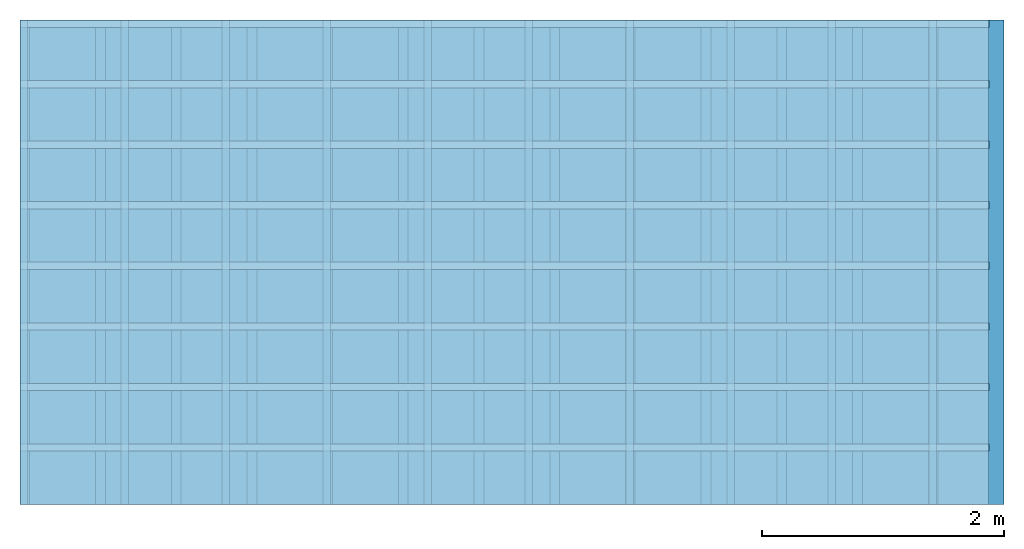
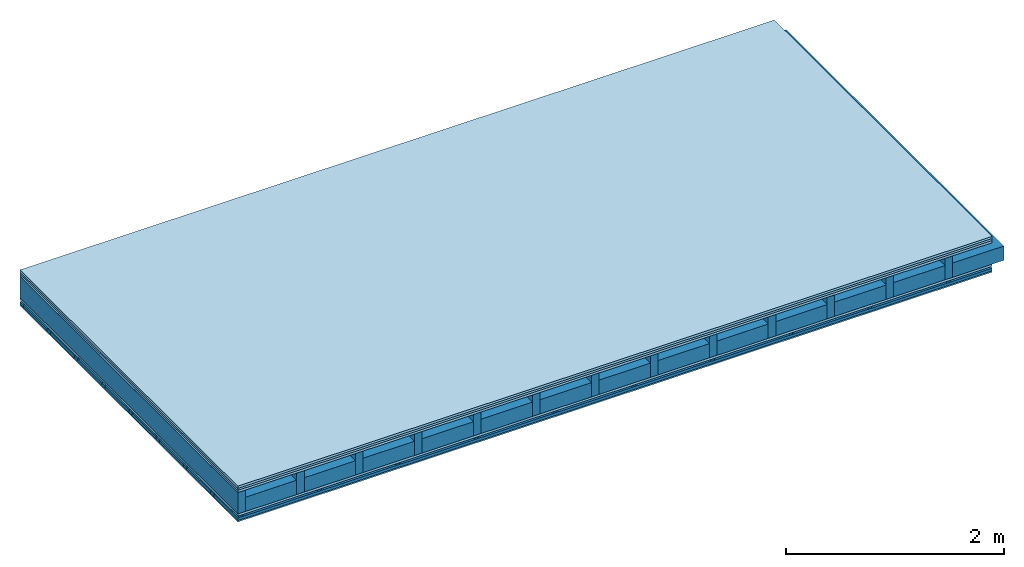
# One storey: 5 members, 5 plates, 1 element without a shape of its own.
"""IFC4 building model written with IfcOpenShell, lengths in metres."""

from ifc_helpers import new_model, si_unit, derived_unit, direction, frame, frame_2d, origin, origin_with_axes, place, context, project, spatial, polyline, rectangle, outline, extrude, material, layer, layer_set, type_object, element, aggregate, save


model = new_model("IFC4")

# Units and contexts
plan_context = context("Plan", 3, precision=1e-05, world=origin(), true_north=direction((0.0, 1.0)))
model_context = context("Model", 3, precision=1e-05, world=origin(), true_north=direction((0.0, 1.0)))
ifc_project = project(units=[si_unit("LENGTHUNIT", "METRE"), derived_unit("SOUNDPRESSUREUNIT", [(si_unit("PRESSUREUNIT", "PASCAL", prefix="MICRO"), 0)]), si_unit("ENERGYUNIT", "JOULE", prefix="MEGA"), si_unit("MASSUNIT", "GRAM", prefix="KILO"), derived_unit("THERMALTRANSMITTANCEUNIT", [(si_unit("POWERUNIT", "WATT"), 1), (si_unit("AREAUNIT", "SQUARE_METRE"), -1), (si_unit("THERMODYNAMICTEMPERATUREUNIT", "KELVIN"), -1)]), derived_unit("AREADENSITYUNIT", [(si_unit("MASSUNIT", "GRAM", prefix="KILO"), 1), (si_unit("AREAUNIT", "SQUARE_METRE"), -1)]), derived_unit("USERDEFINED", [(si_unit("ENERGYUNIT", "JOULE", prefix="MEGA"), 1), (si_unit("AREAUNIT", "SQUARE_METRE"), -1)])], contexts=[plan_context, model_context])

# Site, building, storey
site = spatial("IfcSite", under=ifc_project)
building_placement = place(None, origin())
building = spatial("IfcBuilding", under=site, at=building_placement)
storey_placement = place(building_placement, origin())
storey = spatial("IfcBuildingStorey", under=building, at=storey_placement)

# Slab, members, plates
ifc_material_1 = material(Name="Floor heating system Therm38 longitudinal", Category="03.007")
ifc_layer_1 = layer(ifc_material_1, 0.025, Name="On-material")
ifc_material_2 = material(Category="10.009")
ifc_layer_2 = layer(ifc_material_2, 0.022, Name="Impact sound insulation")
ifc_material_3 = material(Category="07.001")
ifc_layer_3 = layer(ifc_material_3, 0.025, Name="Sub-floor")
ifc_material_4 = material(Name="Rigid, of the art")
ifc_layer_4 = layer(ifc_material_4, 0.0, Name="Bond")
ifc_layer_5 = layer(None, 0.24, Name="Supporting structure")
ifc_layer_6 = layer(ifc_material_4, 0.0, Name="Bond")
ifc_layer_7 = layer(ifc_material_3, 0.025, Name="Lower layer 1")
ifc_layer_8 = layer(None, 0.02, Name="Coupling")
ifc_layer_9 = layer(None, 0.03, Name="Battens / profiles")
ifc_material_5 = material(Category="03.007")
ifc_layer_10 = layer(ifc_material_5, 0.015, Name="Ceiling covering 1st layer")
ifc_material_6 = material(Name="Glued joints")
ifc_layer_11 = layer(ifc_material_6, 0.0, Name="Surface / treatment")
ifc_layer_set = layer_set([ifc_layer_1, ifc_layer_2, ifc_layer_3, ifc_layer_4, ifc_layer_5, ifc_layer_6, ifc_layer_7, ifc_layer_8, ifc_layer_9, ifc_layer_10, ifc_layer_11])
slab_type = type_object("IfcSlabType", Name="A0322", PredefinedType="NOTDEFINED", material=ifc_layer_set)
slab_placement = place(None, frame((0.0, 0.0, 0.0), z_axis=(0.0, 0.0, -1.0), x_axis=(1.0, 0.0, 0.0)))
slab = element("IfcSlab", 1, at=slab_placement, inside=storey, type_object=slab_type, material=ifc_layer_set, Name="Slab #1")
ifc_material_7 = material()
member_1_placement = place(slab_placement, origin())
member_1 = element("IfcMember", 2, at=member_1_placement, material=ifc_material_7, Name="Supporting structure", context=plan_context, shape_type="SweptSolid", body=[
    extrude(rectangle(XDim=0.08, YDim=0.24, at=frame_2d((0.04, 0.12), x_axis=(1.0, 0.0))), frame((0.0, 4.0, 0.072), z_axis=(0.0, -1.0, 0.0), x_axis=(1.0, 0.0, 0.0)), (0.0, 0.0, 1.0), 4.0),
    extrude(rectangle(XDim=0.08, YDim=0.24, at=frame_2d((0.04, 0.12), x_axis=(1.0, 0.0))), frame((0.625, 4.0, 0.072), z_axis=(0.0, -1.0, 0.0), x_axis=(1.0, 0.0, 0.0)), (0.0, 0.0, 1.0), 4.0),
    extrude(rectangle(XDim=0.08, YDim=0.24, at=frame_2d((0.04, 0.12), x_axis=(1.0, 0.0))), frame((1.25, 4.0, 0.072), z_axis=(0.0, -1.0, 0.0), x_axis=(1.0, 0.0, 0.0)), (0.0, 0.0, 1.0), 4.0),
    extrude(rectangle(XDim=0.08, YDim=0.24, at=frame_2d((0.04, 0.12), x_axis=(1.0, 0.0))), frame((1.875, 4.0, 0.072), z_axis=(0.0, -1.0, 0.0), x_axis=(1.0, 0.0, 0.0)), (0.0, 0.0, 1.0), 4.0),
    extrude(rectangle(XDim=0.08, YDim=0.24, at=frame_2d((0.04, 0.12), x_axis=(1.0, 0.0))), frame((2.5, 4.0, 0.072), z_axis=(0.0, -1.0, 0.0), x_axis=(1.0, 0.0, 0.0)), (0.0, 0.0, 1.0), 4.0),
    extrude(rectangle(XDim=0.08, YDim=0.24, at=frame_2d((0.04, 0.12), x_axis=(1.0, 0.0))), frame((3.125, 4.0, 0.072), z_axis=(0.0, -1.0, 0.0), x_axis=(1.0, 0.0, 0.0)), (0.0, 0.0, 1.0), 4.0),
    extrude(rectangle(XDim=0.08, YDim=0.24, at=frame_2d((0.04, 0.12), x_axis=(1.0, 0.0))), frame((3.75, 4.0, 0.072), z_axis=(0.0, -1.0, 0.0), x_axis=(1.0, 0.0, 0.0)), (0.0, 0.0, 1.0), 4.0),
    extrude(rectangle(XDim=0.08, YDim=0.24, at=frame_2d((0.04, 0.12), x_axis=(1.0, 0.0))), frame((4.375, 4.0, 0.072), z_axis=(0.0, -1.0, 0.0), x_axis=(1.0, 0.0, 0.0)), (0.0, 0.0, 1.0), 4.0),
    extrude(rectangle(XDim=0.08, YDim=0.24, at=frame_2d((0.04, 0.12), x_axis=(1.0, 0.0))), frame((5.0, 4.0, 0.072), z_axis=(0.0, -1.0, 0.0), x_axis=(1.0, 0.0, 0.0)), (0.0, 0.0, 1.0), 4.0),
    extrude(rectangle(XDim=0.08, YDim=0.24, at=frame_2d((0.04, 0.12), x_axis=(1.0, 0.0))), frame((5.625, 4.0, 0.072), z_axis=(0.0, -1.0, 0.0), x_axis=(1.0, 0.0, 0.0)), (0.0, 0.0, 1.0), 4.0),
    extrude(rectangle(XDim=0.08, YDim=0.24, at=frame_2d((0.04, 0.12), x_axis=(1.0, 0.0))), frame((6.25, 4.0, 0.072), z_axis=(0.0, -1.0, 0.0), x_axis=(1.0, 0.0, 0.0)), (0.0, 0.0, 1.0), 4.0),
    extrude(rectangle(XDim=0.08, YDim=0.24, at=frame_2d((0.04, 0.12), x_axis=(1.0, 0.0))), frame((6.875, 4.0, 0.072), z_axis=(0.0, -1.0, 0.0), x_axis=(1.0, 0.0, 0.0)), (0.0, 0.0, 1.0), 4.0),
    extrude(rectangle(XDim=0.08, YDim=0.24, at=frame_2d((0.04, 0.12), x_axis=(1.0, 0.0))), frame((7.5, 4.0, 0.072), z_axis=(0.0, -1.0, 0.0), x_axis=(1.0, 0.0, 0.0)), (0.0, 0.0, 1.0), 4.0),
])
ifc_material_8 = material()
member_2_placement = place(slab_placement, origin())
member_2 = element("IfcMember", 3, at=member_2_placement, material=ifc_material_8, Name="Cavity", context=plan_context, shape_type="SweptSolid", body=[
    extrude(rectangle(XDim=0.545, YDim=0.16, at=frame_2d((0.2725, 0.08), x_axis=(1.0, 0.0))), frame((0.08, 4.0, 0.152), z_axis=(0.0, -1.0, 0.0), x_axis=(1.0, 0.0, 0.0)), (0.0, 0.0, 1.0), 4.0),
    extrude(rectangle(XDim=0.545, YDim=0.16, at=frame_2d((0.2725, 0.08), x_axis=(1.0, 0.0))), frame((0.705, 4.0, 0.152), z_axis=(0.0, -1.0, 0.0), x_axis=(1.0, 0.0, 0.0)), (0.0, 0.0, 1.0), 4.0),
    extrude(rectangle(XDim=0.545, YDim=0.16, at=frame_2d((0.2725, 0.08), x_axis=(1.0, 0.0))), frame((1.33, 4.0, 0.152), z_axis=(0.0, -1.0, 0.0), x_axis=(1.0, 0.0, 0.0)), (0.0, 0.0, 1.0), 4.0),
    extrude(rectangle(XDim=0.545, YDim=0.16, at=frame_2d((0.2725, 0.08), x_axis=(1.0, 0.0))), frame((1.955, 4.0, 0.152), z_axis=(0.0, -1.0, 0.0), x_axis=(1.0, 0.0, 0.0)), (0.0, 0.0, 1.0), 4.0),
    extrude(rectangle(XDim=0.545, YDim=0.16, at=frame_2d((0.2725, 0.08), x_axis=(1.0, 0.0))), frame((2.58, 4.0, 0.152), z_axis=(0.0, -1.0, 0.0), x_axis=(1.0, 0.0, 0.0)), (0.0, 0.0, 1.0), 4.0),
    extrude(rectangle(XDim=0.545, YDim=0.16, at=frame_2d((0.2725, 0.08), x_axis=(1.0, 0.0))), frame((3.205, 4.0, 0.152), z_axis=(0.0, -1.0, 0.0), x_axis=(1.0, 0.0, 0.0)), (0.0, 0.0, 1.0), 4.0),
    extrude(rectangle(XDim=0.545, YDim=0.16, at=frame_2d((0.2725, 0.08), x_axis=(1.0, 0.0))), frame((3.83, 4.0, 0.152), z_axis=(0.0, -1.0, 0.0), x_axis=(1.0, 0.0, 0.0)), (0.0, 0.0, 1.0), 4.0),
    extrude(rectangle(XDim=0.545, YDim=0.16, at=frame_2d((0.2725, 0.08), x_axis=(1.0, 0.0))), frame((4.455, 4.0, 0.152), z_axis=(0.0, -1.0, 0.0), x_axis=(1.0, 0.0, 0.0)), (0.0, 0.0, 1.0), 4.0),
    extrude(rectangle(XDim=0.545, YDim=0.16, at=frame_2d((0.2725, 0.08), x_axis=(1.0, 0.0))), frame((5.08, 4.0, 0.152), z_axis=(0.0, -1.0, 0.0), x_axis=(1.0, 0.0, 0.0)), (0.0, 0.0, 1.0), 4.0),
    extrude(rectangle(XDim=0.545, YDim=0.16, at=frame_2d((0.2725, 0.08), x_axis=(1.0, 0.0))), frame((5.705, 4.0, 0.152), z_axis=(0.0, -1.0, 0.0), x_axis=(1.0, 0.0, 0.0)), (0.0, 0.0, 1.0), 4.0),
    extrude(rectangle(XDim=0.545, YDim=0.16, at=frame_2d((0.2725, 0.08), x_axis=(1.0, 0.0))), frame((6.33, 4.0, 0.152), z_axis=(0.0, -1.0, 0.0), x_axis=(1.0, 0.0, 0.0)), (0.0, 0.0, 1.0), 4.0),
    extrude(rectangle(XDim=0.545, YDim=0.16, at=frame_2d((0.2725, 0.08), x_axis=(1.0, 0.0))), frame((6.955, 4.0, 0.152), z_axis=(0.0, -1.0, 0.0), x_axis=(1.0, 0.0, 0.0)), (0.0, 0.0, 1.0), 4.0),
    extrude(rectangle(XDim=0.545, YDim=0.16, at=frame_2d((0.2725, 0.08), x_axis=(1.0, 0.0))), frame((7.58, 4.0, 0.152), z_axis=(0.0, -1.0, 0.0), x_axis=(1.0, 0.0, 0.0)), (0.0, 0.0, 1.0), 4.0),
])
ifc_material_9 = material()
member_3_placement = place(slab_placement, origin())
member_3 = element("IfcMember", 4, at=member_3_placement, material=ifc_material_9, Name="Coupling", context=plan_context, shape_type="SweptSolid", body=[
    extrude(outline(polyline([(0.0, 0.0), (0.06, 0.0), (0.04, 0.02), (0.02, 0.02), (0.0, 0.0)])), frame((0.0, 4.0, 0.337), z_axis=(0.0, -1.0, 0.0), x_axis=(1.0, 0.0, 0.0)), (0.0, 0.0, 1.0), 4.0),
    extrude(outline(polyline([(0.0, 0.0), (0.06, 0.0), (0.04, 0.02), (0.02, 0.02), (0.0, 0.0)])), frame((0.834, 4.0, 0.337), z_axis=(0.0, -1.0, 0.0), x_axis=(1.0, 0.0, 0.0)), (0.0, 0.0, 1.0), 4.0),
    extrude(outline(polyline([(0.0, 0.0), (0.06, 0.0), (0.04, 0.02), (0.02, 0.02), (0.0, 0.0)])), frame((1.668, 4.0, 0.337), z_axis=(0.0, -1.0, 0.0), x_axis=(1.0, 0.0, 0.0)), (0.0, 0.0, 1.0), 4.0),
    extrude(outline(polyline([(0.0, 0.0), (0.06, 0.0), (0.04, 0.02), (0.02, 0.02), (0.0, 0.0)])), frame((2.502, 4.0, 0.337), z_axis=(0.0, -1.0, 0.0), x_axis=(1.0, 0.0, 0.0)), (0.0, 0.0, 1.0), 4.0),
    extrude(outline(polyline([(0.0, 0.0), (0.06, 0.0), (0.04, 0.02), (0.02, 0.02), (0.0, 0.0)])), frame((3.336, 4.0, 0.337), z_axis=(0.0, -1.0, 0.0), x_axis=(1.0, 0.0, 0.0)), (0.0, 0.0, 1.0), 4.0),
    extrude(outline(polyline([(0.0, 0.0), (0.06, 0.0), (0.04, 0.02), (0.02, 0.02), (0.0, 0.0)])), frame((4.17, 4.0, 0.337), z_axis=(0.0, -1.0, 0.0), x_axis=(1.0, 0.0, 0.0)), (0.0, 0.0, 1.0), 4.0),
    extrude(outline(polyline([(0.0, 0.0), (0.06, 0.0), (0.04, 0.02), (0.02, 0.02), (0.0, 0.0)])), frame((5.004, 4.0, 0.337), z_axis=(0.0, -1.0, 0.0), x_axis=(1.0, 0.0, 0.0)), (0.0, 0.0, 1.0), 4.0),
    extrude(outline(polyline([(0.0, 0.0), (0.06, 0.0), (0.04, 0.02), (0.02, 0.02), (0.0, 0.0)])), frame((5.838, 4.0, 0.337), z_axis=(0.0, -1.0, 0.0), x_axis=(1.0, 0.0, 0.0)), (0.0, 0.0, 1.0), 4.0),
    extrude(outline(polyline([(0.0, 0.0), (0.06, 0.0), (0.04, 0.02), (0.02, 0.02), (0.0, 0.0)])), frame((6.672, 4.0, 0.337), z_axis=(0.0, -1.0, 0.0), x_axis=(1.0, 0.0, 0.0)), (0.0, 0.0, 1.0), 4.0),
    extrude(outline(polyline([(0.0, 0.0), (0.06, 0.0), (0.04, 0.02), (0.02, 0.02), (0.0, 0.0)])), frame((7.506, 4.0, 0.337), z_axis=(0.0, -1.0, 0.0), x_axis=(1.0, 0.0, 0.0)), (0.0, 0.0, 1.0), 4.0),
])
ifc_material_10 = material()
member_4_placement = place(slab_placement, origin())
member_4 = element("IfcMember", 5, at=member_4_placement, material=ifc_material_10, Name="Battens / profiles", context=plan_context, shape_type="SweptSolid", body=[
    extrude(rectangle(XDim=0.06, YDim=0.03, at=frame_2d((0.03, 0.015), x_axis=(1.0, 0.0))), frame((0.0, 0.0, 0.357), z_axis=(1.0, 0.0, 0.0), x_axis=(0.0, 1.0, 0.0)), (0.0, 0.0, 1.0), 8.0),
    extrude(rectangle(XDim=0.06, YDim=0.03, at=frame_2d((0.03, 0.015), x_axis=(1.0, 0.0))), frame((0.0, 0.5, 0.357), z_axis=(1.0, 0.0, 0.0), x_axis=(0.0, 1.0, 0.0)), (0.0, 0.0, 1.0), 8.0),
    extrude(rectangle(XDim=0.06, YDim=0.03, at=frame_2d((0.03, 0.015), x_axis=(1.0, 0.0))), frame((0.0, 1.0, 0.357), z_axis=(1.0, 0.0, 0.0), x_axis=(0.0, 1.0, 0.0)), (0.0, 0.0, 1.0), 8.0),
    extrude(rectangle(XDim=0.06, YDim=0.03, at=frame_2d((0.03, 0.015), x_axis=(1.0, 0.0))), frame((0.0, 1.5, 0.357), z_axis=(1.0, 0.0, 0.0), x_axis=(0.0, 1.0, 0.0)), (0.0, 0.0, 1.0), 8.0),
    extrude(rectangle(XDim=0.06, YDim=0.03, at=frame_2d((0.03, 0.015), x_axis=(1.0, 0.0))), frame((0.0, 2.0, 0.357), z_axis=(1.0, 0.0, 0.0), x_axis=(0.0, 1.0, 0.0)), (0.0, 0.0, 1.0), 8.0),
    extrude(rectangle(XDim=0.06, YDim=0.03, at=frame_2d((0.03, 0.015), x_axis=(1.0, 0.0))), frame((0.0, 2.5, 0.357), z_axis=(1.0, 0.0, 0.0), x_axis=(0.0, 1.0, 0.0)), (0.0, 0.0, 1.0), 8.0),
    extrude(rectangle(XDim=0.06, YDim=0.03, at=frame_2d((0.03, 0.015), x_axis=(1.0, 0.0))), frame((0.0, 3.0, 0.357), z_axis=(1.0, 0.0, 0.0), x_axis=(0.0, 1.0, 0.0)), (0.0, 0.0, 1.0), 8.0),
    extrude(rectangle(XDim=0.06, YDim=0.03, at=frame_2d((0.03, 0.015), x_axis=(1.0, 0.0))), frame((0.0, 3.5, 0.357), z_axis=(1.0, 0.0, 0.0), x_axis=(0.0, 1.0, 0.0)), (0.0, 0.0, 1.0), 8.0),
])
member_5_placement = place(slab_placement, origin())
member_5 = element("IfcMember", 6, at=member_5_placement, material=ifc_material_8, Name="Cavity", context=plan_context, shape_type="SweptSolid", body=[
    extrude(rectangle(XDim=0.44, YDim=0.03, at=frame_2d((0.22, 0.015), x_axis=(1.0, 0.0))), frame((0.0, 0.06, 0.357), z_axis=(1.0, 0.0, 0.0), x_axis=(0.0, 1.0, 0.0)), (0.0, 0.0, 1.0), 8.0),
    extrude(rectangle(XDim=0.44, YDim=0.03, at=frame_2d((0.22, 0.015), x_axis=(1.0, 0.0))), frame((0.0, 0.56, 0.357), z_axis=(1.0, 0.0, 0.0), x_axis=(0.0, 1.0, 0.0)), (0.0, 0.0, 1.0), 8.0),
    extrude(rectangle(XDim=0.44, YDim=0.03, at=frame_2d((0.22, 0.015), x_axis=(1.0, 0.0))), frame((0.0, 1.06, 0.357), z_axis=(1.0, 0.0, 0.0), x_axis=(0.0, 1.0, 0.0)), (0.0, 0.0, 1.0), 8.0),
    extrude(rectangle(XDim=0.44, YDim=0.03, at=frame_2d((0.22, 0.015), x_axis=(1.0, 0.0))), frame((0.0, 1.56, 0.357), z_axis=(1.0, 0.0, 0.0), x_axis=(0.0, 1.0, 0.0)), (0.0, 0.0, 1.0), 8.0),
    extrude(rectangle(XDim=0.44, YDim=0.03, at=frame_2d((0.22, 0.015), x_axis=(1.0, 0.0))), frame((0.0, 2.06, 0.357), z_axis=(1.0, 0.0, 0.0), x_axis=(0.0, 1.0, 0.0)), (0.0, 0.0, 1.0), 8.0),
    extrude(rectangle(XDim=0.44, YDim=0.03, at=frame_2d((0.22, 0.015), x_axis=(1.0, 0.0))), frame((0.0, 2.56, 0.357), z_axis=(1.0, 0.0, 0.0), x_axis=(0.0, 1.0, 0.0)), (0.0, 0.0, 1.0), 8.0),
    extrude(rectangle(XDim=0.44, YDim=0.03, at=frame_2d((0.22, 0.015), x_axis=(1.0, 0.0))), frame((0.0, 3.06, 0.357), z_axis=(1.0, 0.0, 0.0), x_axis=(0.0, 1.0, 0.0)), (0.0, 0.0, 1.0), 8.0),
    extrude(rectangle(XDim=0.44, YDim=0.03, at=frame_2d((0.22, 0.015), x_axis=(1.0, 0.0))), frame((0.0, 3.56, 0.357), z_axis=(1.0, 0.0, 0.0), x_axis=(0.0, 1.0, 0.0)), (0.0, 0.0, 1.0), 8.0),
])
plate_1_placement = place(slab_placement, origin())
plate_1 = element("IfcPlate", 7, at=plate_1_placement, material=ifc_material_1, Name="On-material", context=plan_context, shape_type="SweptSolid", body=[
    extrude(rectangle(XDim=8.0, YDim=4.0, at=frame_2d((4.0, 2.0), x_axis=(1.0, 0.0))), origin_with_axes(), (0.0, 0.0, 1.0), 0.025),
])
plate_2_placement = place(slab_placement, origin())
plate_2 = element("IfcPlate", 8, at=plate_2_placement, material=ifc_material_2, Name="Impact sound insulation", context=plan_context, shape_type="SweptSolid", body=[
    extrude(rectangle(XDim=8.0, YDim=4.0, at=frame_2d((4.0, 2.0), x_axis=(1.0, 0.0))), frame((0.0, 0.0, 0.025), z_axis=(0.0, 0.0, 1.0), x_axis=(1.0, 0.0, 0.0)), (0.0, 0.0, 1.0), 0.022),
])
plate_3_placement = place(slab_placement, origin())
plate_3 = element("IfcPlate", 9, at=plate_3_placement, material=ifc_material_3, Name="Sub-floor", context=plan_context, shape_type="SweptSolid", body=[
    extrude(rectangle(XDim=8.0, YDim=4.0, at=frame_2d((4.0, 2.0), x_axis=(1.0, 0.0))), frame((0.0, 0.0, 0.047), z_axis=(0.0, 0.0, 1.0), x_axis=(1.0, 0.0, 0.0)), (0.0, 0.0, 1.0), 0.025),
])
plate_4_placement = place(slab_placement, origin())
plate_4 = element("IfcPlate", 10, at=plate_4_placement, material=ifc_material_3, Name="Lower layer 1", context=plan_context, shape_type="SweptSolid", body=[
    extrude(rectangle(XDim=8.0, YDim=4.0, at=frame_2d((4.0, 2.0), x_axis=(1.0, 0.0))), frame((0.0, 0.0, 0.312), z_axis=(0.0, 0.0, 1.0), x_axis=(1.0, 0.0, 0.0)), (0.0, 0.0, 1.0), 0.025),
])
plate_5_placement = place(slab_placement, origin())
plate_5 = element("IfcPlate", 11, at=plate_5_placement, material=ifc_material_5, Name="Ceiling covering 1st layer", context=plan_context, shape_type="SweptSolid", body=[
    extrude(rectangle(XDim=8.0, YDim=4.0, at=frame_2d((4.0, 2.0), x_axis=(1.0, 0.0))), frame((0.0, 0.0, 0.387), z_axis=(0.0, 0.0, 1.0), x_axis=(1.0, 0.0, 0.0)), (0.0, 0.0, 1.0), 0.015),
])
aggregate(slab, [plate_1, plate_2, plate_3, member_1, member_2, plate_4, member_3, member_4, member_5, plate_5])

save(model, "model.ifc")
